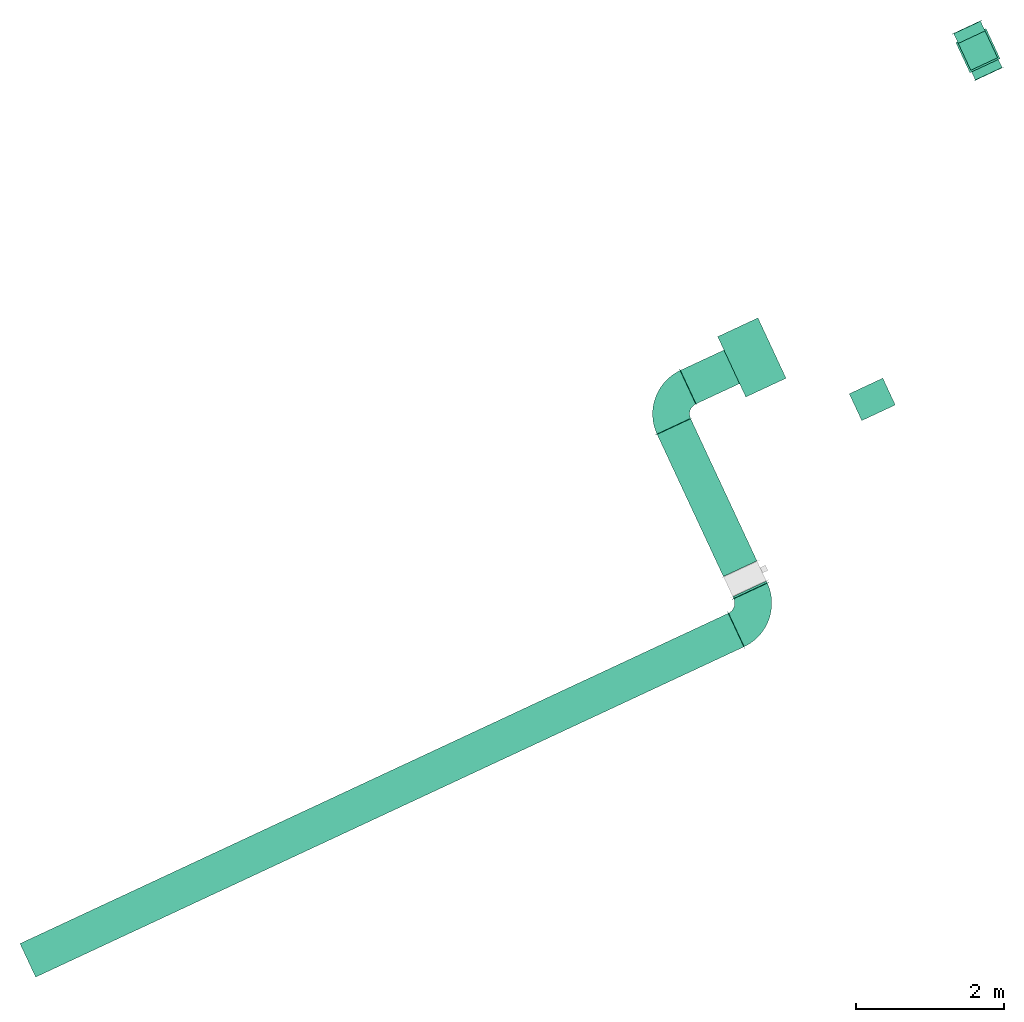
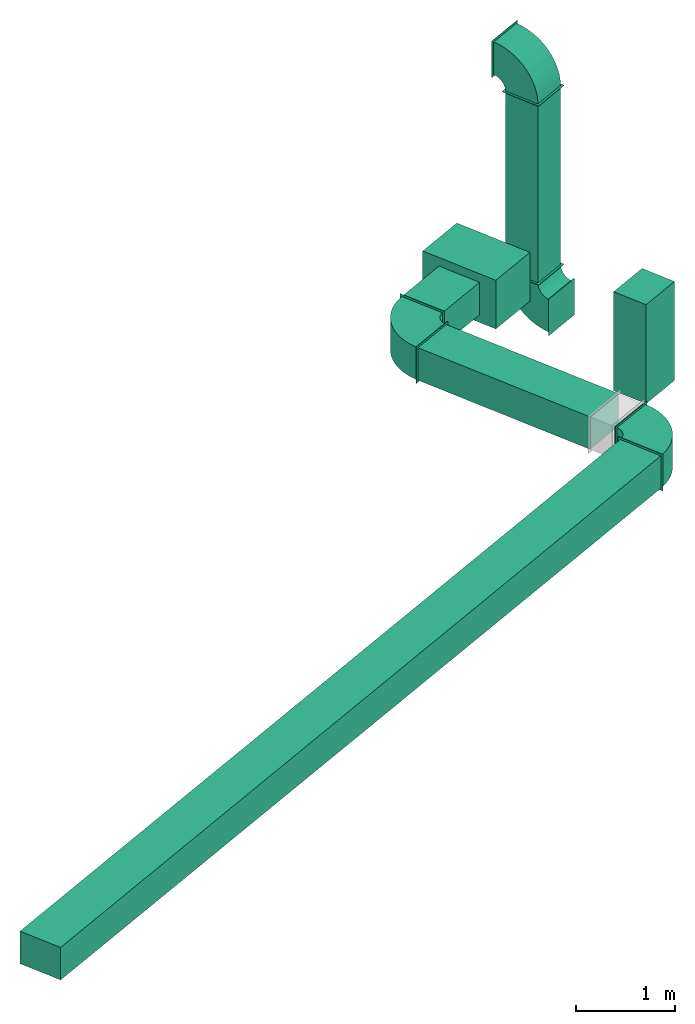
# One storey, part 1 of 2: 6 flow segments, 4 flow fittings, 1 energy conversion device.
"""IFC2X3 building model written with IfcOpenShell, lengths in metres."""

from ifc_helpers import new_model, entity, si_unit, converted_unit, derived_unit, direction, frame, frame_2d, origin, origin_2d_with_axis, place, context, subcontext, project, spatial, polyline, circle_curve, parameter, trimmed, segment, composite_curve, rectangle, outline, extrude, source, transform, mapped, material, material_list, type_object, type_shapes, element, save


model = new_model("IFC2X3")

# Units and contexts
model_context = context("Model", 3, precision=1e-05, world=origin(), true_north=direction((6.12303176911189e-17, 1.0)))
body_context = subcontext(model_context, "Body", "Model", "MODEL_VIEW")
ifc_project = project(units=[si_unit("LENGTHUNIT", "METRE"), si_unit("AREAUNIT", "SQUARE_METRE"), si_unit("VOLUMEUNIT", "CUBIC_METRE"), converted_unit("PLANEANGLEUNIT", "DEGREE", entity("IfcRatioMeasure", 0.0174532925199433), si_unit("PLANEANGLEUNIT", "RADIAN"), dimensions=[0, 0, 0, 0, 0, 0, 0]), si_unit("MASSUNIT", "GRAM", prefix="KILO"), derived_unit("MASSDENSITYUNIT", [(si_unit("MASSUNIT", "GRAM", prefix="KILO"), 1), (si_unit("LENGTHUNIT", "METRE"), -3)]), si_unit("TIMEUNIT", "SECOND"), si_unit("FREQUENCYUNIT", "HERTZ"), si_unit("THERMODYNAMICTEMPERATUREUNIT", "DEGREE_CELSIUS"), derived_unit("THERMALTRANSMITTANCEUNIT", [(si_unit("MASSUNIT", "GRAM", prefix="KILO"), 1), (si_unit("THERMODYNAMICTEMPERATUREUNIT", "KELVIN"), -1), (si_unit("TIMEUNIT", "SECOND"), -3)]), derived_unit("VOLUMETRICFLOWRATEUNIT", [(si_unit("LENGTHUNIT", "METRE"), 3), (si_unit("TIMEUNIT", "SECOND"), -1)]), si_unit("ELECTRICCURRENTUNIT", "AMPERE"), si_unit("ELECTRICVOLTAGEUNIT", "VOLT"), si_unit("POWERUNIT", "WATT"), si_unit("FORCEUNIT", "NEWTON", prefix="KILO"), si_unit("ILLUMINANCEUNIT", "LUX"), si_unit("LUMINOUSFLUXUNIT", "LUMEN"), si_unit("LUMINOUSINTENSITYUNIT", "CANDELA"), derived_unit("USERDEFINED", [(si_unit("MASSUNIT", "GRAM", prefix="KILO"), -1), (si_unit("LENGTHUNIT", "METRE"), -2), (si_unit("TIMEUNIT", "SECOND"), 3), (si_unit("LUMINOUSFLUXUNIT", "LUMEN"), 1)]), derived_unit("LINEARVELOCITYUNIT", [(si_unit("LENGTHUNIT", "METRE"), 1), (si_unit("TIMEUNIT", "SECOND"), -1)]), si_unit("PRESSUREUNIT", "PASCAL"), derived_unit("USERDEFINED", [(si_unit("LENGTHUNIT", "METRE"), -2), (si_unit("MASSUNIT", "GRAM", prefix="KILO"), 1), (si_unit("TIMEUNIT", "SECOND"), -2)])], contexts=[model_context])

# Site, building, storey
site_placement = place(None, frame((-27.6339874998918, 64.4092442595216, 0.0), z_axis=(0.0, 0.0, 1.0), x_axis=(-0.422618261740703, 0.906307787036648, 0.0)))
site = spatial("IfcSite", under=ifc_project, at=site_placement, CompositionType="ELEMENT")
building_placement = place(site_placement, origin())
building = spatial("IfcBuilding", under=site, at=building_placement, CompositionType="ELEMENT")
storey_placement = place(building_placement, frame((0.0, 0.0, 2.56)))
storey = spatial("IfcBuildingStorey", under=building, at=storey_placement, CompositionType="ELEMENT", Elevation=2.56)

# Flow segments
distribution_element_type_1 = type_object("IfcDistributionElementType", Name="Gaine rectangulaire:CVC_27_26_Gaine rectangulaire")
flow_segment_1_placement = place(storey_placement, origin())
element("IfcFlowSegment", 1, at=flow_segment_1_placement, inside=storey, type_object=distribution_element_type_1, Name="Gaine rectangulaire:27_26_Gaine rectangulaire", ObjectType="Gaine rectangulaire:CVC_27_26_Gaine rectangulaire", context=body_context, shape_type="SweptSolid", body=[
    extrude(rectangle(XDim=0.4, YDim=0.4, at=origin_2d_with_axis()), frame((-16.112523945828, 14.1713389501772, -1.90900000000008), z_axis=(0.0, -7.36239190738175e-07, 1.0), x_axis=(-1.0, 0.0, 0.0)), (0.0, 0.0, 1.0), 2.19800000000152),
])
flow_segment_2_placement = place(storey_placement, origin())
element("IfcFlowSegment", 2, at=flow_segment_2_placement, inside=storey, type_object=distribution_element_type_1, Name="Gaine rectangulaire:27_26_Gaine rectangulaire", ObjectType="Gaine rectangulaire:CVC_27_26_Gaine rectangulaire", context=body_context, shape_type="SweptSolid", body=[
    extrude(rectangle(XDim=10.559, YDim=0.499999999999999, at=frame_2d((0.0, -2.17881268582687e-15), x_axis=(1.0, 0.0))), frame((-21.8282328445591, 25.7221272162196, 1.36000262207879), z_axis=(0.0, 0.0, 1.0), x_axis=(0.0, 1.0, 0.0)), (0.0, 0.0, 1.0), 0.4),
])
flow_segment_3_placement = place(storey_placement, origin())
element("IfcFlowSegment", 3, at=flow_segment_3_placement, inside=storey, type_object=distribution_element_type_1, Name="Gaine rectangulaire:27_26_Gaine rectangulaire", ObjectType="Gaine rectangulaire:CVC_27_26_Gaine rectangulaire", context=body_context, shape_type="SweptSolid", body=[
    extrude(rectangle(XDim=2.11958841978643, YDim=0.499999999999999, at=frame_2d((9.99200722162641e-16, 0.0), x_axis=(1.0, 0.0))), frame((-20.0404280664787, 20.0416272162196, 1.36000203816505)), (0.0, 0.0, 1.0), 0.4),
])
flow_segment_4_placement = place(storey_placement, origin())
element("IfcFlowSegment", 4, at=flow_segment_4_placement, inside=storey, type_object=distribution_element_type_1, Name="Gaine rectangulaire:27_26_Gaine rectangulaire", ObjectType="Gaine rectangulaire:CVC_27_26_Gaine rectangulaire", context=body_context, shape_type="SweptSolid", body=[
    extrude(rectangle(XDim=0.399999999999996, YDim=0.499999999999999, at=origin_2d_with_axis()), frame((-19.7806372056741, 17.4567587819605, -0.00999999999999989), z_axis=(0.0, 0.0, 1.0), x_axis=(-1.0, 0.0, 0.0)), (0.0, 0.0, 1.0), 1.219),
])
flow_segment_5_placement = place(storey_placement, origin())
element("IfcFlowSegment", 5, at=flow_segment_5_placement, inside=storey, type_object=distribution_element_type_1, Name="Gaine rectangulaire:27_26_Gaine rectangulaire", ObjectType="Gaine rectangulaire:CVC_27_26_Gaine rectangulaire", context=body_context, shape_type="SweptSolid", body=[
    extrude(rectangle(XDim=0.026986632137752, YDim=0.499999999999999, at=frame_2d((-2.16580225975704e-15, 0.0), x_axis=(1.0, 0.0))), frame((-21.4137395284903, 20.0416272162196, 1.36000230345649)), (0.0, 0.0, 1.0), 0.4),
])
flow_segment_6_placement = place(storey_placement, origin())
element("IfcFlowSegment", 6, at=flow_segment_6_placement, inside=storey, type_object=distribution_element_type_1, Name="Gaine rectangulaire:27_26_Gaine rectangulaire", ObjectType="Gaine rectangulaire:CVC_27_26_Gaine rectangulaire", context=body_context, shape_type="SweptSolid", body=[
    extrude(rectangle(XDim=0.648731674679799, YDim=0.499999999999999, at=frame_2d((1.08246744900953e-15, 0.0), x_axis=(1.0, 0.0))), frame((-18.5796338565856, 19.3162613788797, 1.35999999330601), z_axis=(0.0, 0.0, 1.0), x_axis=(0.0, -1.0, 0.0)), (0.0, 0.0, 1.0), 0.4),
])

# Flow fittings
distribution_element_type_2 = type_object("IfcDistributionElementType")
shared_shape_1 = source(origin(), body_context, "Body", "SweptSolid", [
    extrude(rectangle(XDim=0.00500000000000001, YDim=0.45, at=frame_2d((3.38271077815477e-17, -2.77555756156289e-17), x_axis=(1.0, 0.0))), frame((0.0, 0.3485, -0.225), z_axis=(0.0, 0.0, 1.0), x_axis=(0.0, -1.0, 0.0)), (0.0, 0.0, 1.0), 0.45),
    extrude(outline(composite_curve([segment(trimmed(circle_curve(frame_2d((-0.175, 0.175), x_axis=(1.0, 0.0)), 0.55), [parameter(270.0)], [parameter(360.0)], True, "PARAMETER"), True, "CONTINUOUS"), segment(polyline([(0.375, 0.175), (-0.0250000000000002, 0.175)]), True, "CONTINUOUS"), segment(trimmed(circle_curve(frame_2d((-0.175, 0.175), x_axis=(1.0, 0.0)), 0.15), [parameter(270.0)], [parameter(1.52666624710249e-13)], True, "PARAMETER"), False, "CONTINUOUS"), segment(polyline([(-0.175, 0.0249999999999997), (-0.174999999999999, -0.375)]), True, "CONTINUOUS")], self_intersect=False)), frame((-0.174999999999999, 0.175, -0.2)), (0.0, 0.0, 1.0), 0.4),
    extrude(rectangle(XDim=0.000999999999999976, YDim=0.4, at=frame_2d((0.0, -1.38777878078145e-17), x_axis=(1.0, 0.0))), frame((0.0, 0.3505, -0.2), z_axis=(0.0, 0.0, 1.0), x_axis=(0.0, 1.0, 0.0)), (0.0, 0.0, 1.0), 0.4),
    extrude(rectangle(XDim=0.00500000000000001, YDim=0.45, at=frame_2d((3.38271077815477e-17, 0.0), x_axis=(1.0, 0.0))), frame((-0.348500000000009, 0.0, -0.225)), (0.0, 0.0, 1.0), 0.45),
    extrude(rectangle(XDim=0.00100000000000004, YDim=0.4, at=frame_2d((2.50412754768115e-15, 0.0), x_axis=(1.0, 0.0))), frame((-0.350500000000001, 0.0, -0.2), z_axis=(0.0, 0.0, 1.0), x_axis=(-1.0, 0.0, 0.0)), (0.0, 0.0, 1.0), 0.4),
])
type_shapes(distribution_element_type_2, [shared_shape_1])
for number, where, z_axis, x_axis in (
    (7, (-16.112523945828, 14.1713365649654, 0.64), (0.0, -1.0, -2.18506565537358e-06), (-1.0, 0.0, 0.0)),
    (8, (-16.112523945828, 14.1713391870442, -2.26), (0.0, 1.0, 6.74834754424345e-07), (0.0, 6.74834754424345e-07, -1.0)),
):
    element("IfcFlowFitting", number, at=place(storey_placement, frame(where, z_axis=z_axis, x_axis=x_axis)), inside=storey, type_object=distribution_element_type_2, context=body_context, shape_type="MappedRepresentation", body=[
        mapped(shared_shape_1, transform((0.0, 0.0, 0.0), scale=1.0)),
    ])
distribution_element_type_3 = type_object("IfcDistributionElementType")
shared_shape_2 = source(origin(), body_context, "Body", "SweptSolid", [
    extrude(rectangle(XDim=0.00500000000000008, YDim=0.55, at=origin_2d_with_axis()), frame((0.0, 0.3985, -0.225), z_axis=(0.0, 0.0, 1.0), x_axis=(0.0, -1.0, 0.0)), (0.0, 0.0, 1.0), 0.45),
    extrude(outline(composite_curve([segment(trimmed(circle_curve(frame_2d((-0.2, 0.2), x_axis=(1.0, 0.0)), 0.65), [parameter(270.0)], [parameter(0.0)], True, "PARAMETER"), True, "CONTINUOUS"), segment(polyline([(0.45, 0.2), (-0.0500000000000002, 0.2)]), True, "CONTINUOUS"), segment(trimmed(circle_curve(frame_2d((-0.2, 0.2), x_axis=(1.0, 0.0)), 0.15), [parameter(270.0)], [parameter(2.54444374517082e-13)], True, "PARAMETER"), False, "CONTINUOUS"), segment(polyline([(-0.2, 0.0499999999999995), (-0.199999999999999, -0.450000000000001)]), True, "CONTINUOUS")], self_intersect=False)), frame((-0.199999999999999, 0.200000000000001, -0.2)), (0.0, 0.0, 1.0), 0.4),
    extrude(rectangle(XDim=0.00100000000000004, YDim=0.5, at=origin_2d_with_axis()), frame((0.0, 0.4005, -0.2), z_axis=(0.0, 0.0, 1.0), x_axis=(0.0, 1.0, 0.0)), (0.0, 0.0, 1.0), 0.4),
    extrude(rectangle(XDim=0.00500000000000001, YDim=0.55, at=frame_2d((-3.38271077815477e-17, 0.0), x_axis=(1.0, 0.0))), frame((-0.398500000000011, 0.0, -0.225)), (0.0, 0.0, 1.0), 0.45),
    extrude(rectangle(XDim=0.00100000000000004, YDim=0.5, at=frame_2d((3.14711364607367e-15, 0.0), x_axis=(1.0, 0.0))), frame((-0.400500000000002, 0.0, -0.2), z_axis=(0.0, 0.0, 1.0), x_axis=(-1.0, 0.0, 0.0)), (0.0, 0.0, 1.0), 0.4),
])
type_shapes(distribution_element_type_3, [shared_shape_2])
for number, where, z_axis, x_axis in (
    (9, (-21.8282328445591, 20.0416272162196, 1.56000262207879), (7.94569329228402e-07, 0.0, 1.0), (0.0, -1.0, 0.0)),
    (10, (-18.5796338565856, 20.0416272162196, 1.55999999330601), (8.11262570734361e-07, 0.0, 1.0), (0.0, 1.0, 0.0)),
):
    element("IfcFlowFitting", number, at=place(storey_placement, frame(where, z_axis=z_axis, x_axis=x_axis)), inside=storey, type_object=distribution_element_type_3, context=body_context, shape_type="MappedRepresentation", body=[
        mapped(shared_shape_2, transform((0.0, 0.0, 0.0), scale=1.0)),
    ])

# Energy conversion device
ifc_material_1 = material(Name="Glass")
ifc_material_2 = material(Name="Grey")
ifc_material_list_1 = material_list([ifc_material_1, ifc_material_2])
ifc_material_list_2 = material_list([ifc_material_1, ifc_material_2])
distribution_element_type_4 = type_object("IfcDistributionElementType", material=ifc_material_list_2)
shared_shape_3 = source(origin(), body_context, "Body", "SweptSolid", [
    extrude(rectangle(XDim=0.899999999999999, YDim=0.600000000000002, at=origin_2d_with_axis()), frame((0.0, 0.0, 0.0), z_axis=(0.0, 0.0, 1.0), x_axis=(-1.0, 0.0, 0.0)), (0.0, 0.0, 1.0), 0.6),
    extrude(rectangle(XDim=0.899999999999996, YDim=0.600000000000008, at=origin_2d_with_axis()), frame((0.0, 0.0, 0.0), z_axis=(0.0, 0.0, 1.0), x_axis=(-1.0, 0.0, 0.0)), (0.0, 0.0, 1.0), 0.6),
])
type_shapes(distribution_element_type_4, [shared_shape_3])
energy_conversion_device_placement = place(storey_placement, frame((-18.5796338565856, 18.6918955415398, 1.265), z_axis=(0.0, 0.0, 1.0), x_axis=(-1.0, 0.0, 0.0)))
element("IfcEnergyConversionDevice", 11, at=energy_conversion_device_placement, inside=storey, type_object=distribution_element_type_4, material=ifc_material_list_1, Name="22_09_SF1", context=body_context, shape_type="MappedRepresentation", body=[
    mapped(shared_shape_3, transform((0.0, 0.0, 0.0), scale=1.0)),
])

save(model, "model.ifc")
